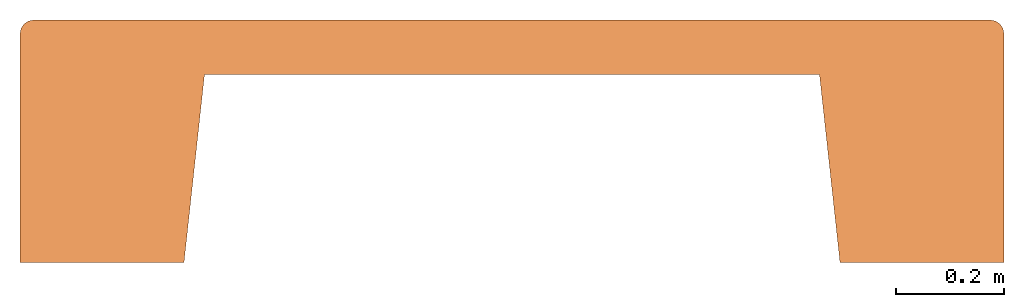
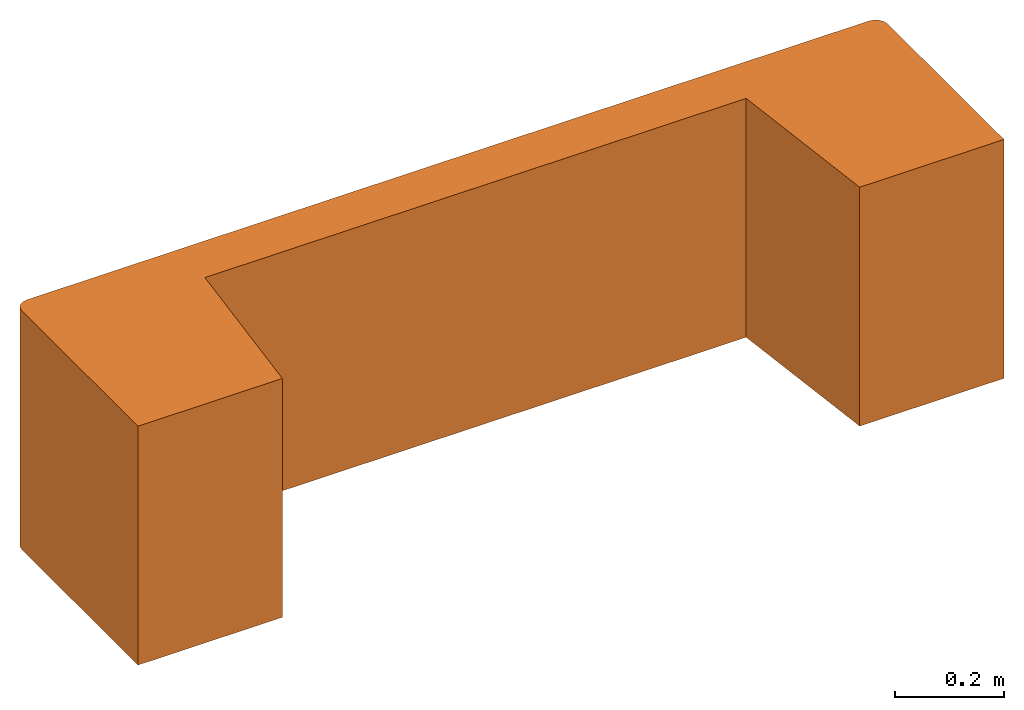
# One storey: 1 proxy.
"""IFC2X3 building model written with IfcOpenShell, lengths in metres."""

from ifc_helpers import new_model, si_unit, direction, origin_with_axes, place, context, project, spatial, faceted_brep, source, transform, mapped, material, element, save


model = new_model("IFC2X3")

# Units and contexts
model_context = context("Model", 3, precision=1e-06, world=origin_with_axes(), true_north=direction((0.0, 1.0, 0.0)))
ifc_project = project(units=[si_unit("LENGTHUNIT", "METRE"), si_unit("AREAUNIT", "SQUARE_METRE"), si_unit("VOLUMEUNIT", "CUBIC_METRE")], contexts=[model_context])

# Site, building, storey
site_placement = place(None, origin_with_axes())
site = spatial("IfcSite", under=ifc_project, at=site_placement, CompositionType="ELEMENT")
building_placement = place(site_placement, origin_with_axes())
building = spatial("IfcBuilding", under=site, at=building_placement, Name="Default Building", CompositionType="ELEMENT")
storey_placement = place(building_placement, origin_with_axes())
storey = spatial("IfcBuildingStorey", under=building, at=storey_placement, Name="Default Storey", CompositionType="ELEMENT", Elevation=0.0)

# Proxy
ifc_material = material(Name="Steel")
shared_shape = source(origin_with_axes(), model_context, "Body", "Brep", [
    faceted_brep([(0.6096000075340271, -3.8882534591728874e-17, 0.26669999957084656), (0.5715000033378601, 0.3492499887943268, 0.26669999957084656), (0.6096000075340271, -3.8882534591728874e-17, -0.26669999957084656), (0.6096000075340271, -3.8882534591728874e-17, -0.26669999957084656), (0.5715000033378601, 0.3492499887943268, 0.26669999957084656), (0.5715000033378601, 0.3492499887943268, -0.26669999957084656), (0.9143999814987183, -1.555301383669155e-18, 0.26669999957084656), (0.6096000075340271, -3.8882534591728874e-17, 0.26669999957084656), (0.9143999814987183, -1.555301383669155e-18, -0.26669999957084656), (0.9143999814987183, -1.555301383669155e-18, -0.26669999957084656), (0.6096000075340271, -3.8882534591728874e-17, 0.26669999957084656), (0.6096000075340271, -3.8882534591728874e-17, -0.26669999957084656), (0.9143999814987183, 0.42544999718666077, 0.26669999957084656), (0.9143999814987183, 0.0, 0.26669999957084656), (0.9143999814987183, 0.42544999718666077, -0.26669999957084656), (0.9143999814987183, 0.42544999718666077, -0.26669999957084656), (0.9143999814987183, 0.0, 0.26669999957084656), (0.9143999814987183, 0.0, -0.26669999957084656), (0.8889999985694885, 0.4508500099182129, -0.26669999957084656), (-0.8889999985694885, 0.4508500099182129, -0.26669999957084656), (0.8889999985694885, 0.4508500099182129, 0.26669999957084656), (0.8889999985694885, 0.4508500099182129, 0.26669999957084656), (-0.8889999985694885, 0.4508500099182129, -0.26669999957084656), (-0.8889999985694885, 0.4508500099182129, 0.26669999957084656), (-0.9143999814987183, 0.42544999718666077, -0.26669999957084656), (-0.9143999814987183, 0.0, -0.26669999957084656), (-0.9143999814987183, 0.42544999718666077, 0.26669999957084656), (-0.9143999814987183, 0.42544999718666077, 0.26669999957084656), (-0.9143999814987183, 0.0, -0.26669999957084656), (-0.9143999814987183, 0.0, 0.26669999957084656), (-0.6096000075340271, -3.8882534591728874e-17, 0.26669999957084656), (-0.9143999814987183, -1.555301383669155e-18, 0.26669999957084656), (-0.6096000075340271, -3.8882534591728874e-17, -0.26669999957084656), (-0.6096000075340271, -3.8882534591728874e-17, -0.26669999957084656), (-0.9143999814987183, -1.555301383669155e-18, 0.26669999957084656), (-0.9143999814987183, -1.555301383669155e-18, -0.26669999957084656), (-0.5715000033378601, 0.3492499887943268, 0.26669999957084656), (-0.6096000075340271, -3.8882534591728874e-17, 0.26669999957084656), (-0.5715000033378601, 0.3492499887943268, -0.26669999957084656), (-0.5715000033378601, 0.3492499887943268, -0.26669999957084656), (-0.6096000075340271, -3.8882534591728874e-17, 0.26669999957084656), (-0.6096000075340271, -3.8882534591728874e-17, -0.26669999957084656), (0.5715000033378601, 0.3492499887943268, 0.26669999957084656), (-0.5715000033378601, 0.3492499887943268, 0.26669999957084656), (0.5715000033378601, 0.3492499887943268, -0.26669999957084656), (0.5715000033378601, 0.3492499887943268, -0.26669999957084656), (-0.5715000033378601, 0.3492499887943268, 0.26669999957084656), (-0.5715000033378601, 0.3492499887943268, -0.26669999957084656), (0.5715000033378601, 0.3492499887943268, 0.26669999957084656), (0.6096000075340271, -3.8882534591728874e-17, 0.26669999957084656), (0.9143999814987183, -1.555301383669155e-18, 0.26669999957084656), (-0.9143999814987183, -1.555301383669155e-18, 0.26669999957084656), (-0.6096000075340271, -3.8882534591728874e-17, 0.26669999957084656), (-0.9143999814987183, 0.42544999718666077, 0.26669999957084656), (-0.9143999814987183, 0.42544999718666077, 0.26669999957084656), (-0.6096000075340271, -3.8882534591728874e-17, 0.26669999957084656), (-0.5715000033378601, 0.3492499887943268, 0.26669999957084656), (-0.9143999814987183, 0.42544999718666077, 0.26669999957084656), (-0.5715000033378601, 0.3492499887943268, 0.26669999957084656), (-0.9124665260314941, 0.43517017364501953, 0.26669999957084656), (-0.9124665260314941, 0.43517017364501953, 0.26669999957084656), (-0.5715000033378601, 0.3492499887943268, 0.26669999957084656), (-0.8987201452255249, 0.44891655445098877, 0.26669999957084656), (-0.9124665260314941, 0.43517017364501953, 0.26669999957084656), (-0.8987201452255249, 0.44891655445098877, 0.26669999957084656), (-0.9069604873657227, 0.4434105157852173, 0.26669999957084656), (0.9143999814987183, -1.555301383669155e-18, 0.26669999957084656), (0.9143999814987183, 0.42544999718666077, 0.26669999957084656), (0.5715000033378601, 0.3492499887943268, 0.26669999957084656), (0.5715000033378601, 0.3492499887943268, 0.26669999957084656), (0.9143999814987183, 0.42544999718666077, 0.26669999957084656), (0.9124665260314941, 0.43517017364501953, 0.26669999957084656), (0.5715000033378601, 0.3492499887943268, 0.26669999957084656), (0.9124665260314941, 0.43517017364501953, 0.26669999957084656), (0.9069604873657227, 0.4434105157852173, 0.26669999957084656), (0.9069604873657227, 0.4434105157852173, 0.26669999957084656), (0.8987201452255249, 0.44891655445098877, 0.26669999957084656), (0.5715000033378601, 0.3492499887943268, 0.26669999957084656), (0.5715000033378601, 0.3492499887943268, 0.26669999957084656), (0.8987201452255249, 0.44891655445098877, 0.26669999957084656), (0.8889999985694885, 0.4508500099182129, 0.26669999957084656), (0.5715000033378601, 0.3492499887943268, 0.26669999957084656), (0.8889999985694885, 0.4508500099182129, 0.26669999957084656), (-0.5715000033378601, 0.3492499887943268, 0.26669999957084656), (-0.5715000033378601, 0.3492499887943268, 0.26669999957084656), (0.8889999985694885, 0.4508500099182129, 0.26669999957084656), (-0.8889999985694885, 0.4508500099182129, 0.26669999957084656), (-0.5715000033378601, 0.3492499887943268, 0.26669999957084656), (-0.8889999985694885, 0.4508500099182129, 0.26669999957084656), (-0.8987201452255249, 0.44891655445098877, 0.26669999957084656), (0.9143999814987183, -1.555301383669155e-18, -0.26669999957084656), (0.6096000075340271, -3.8882534591728874e-17, -0.26669999957084656), (0.9143999814987183, 0.42544999718666077, -0.26669999957084656), (0.9143999814987183, 0.42544999718666077, -0.26669999957084656), (0.6096000075340271, -3.8882534591728874e-17, -0.26669999957084656), (0.5715000033378601, 0.3492499887943268, -0.26669999957084656), (0.9143999814987183, 0.42544999718666077, -0.26669999957084656), (0.5715000033378601, 0.3492499887943268, -0.26669999957084656), (0.9124665260314941, 0.43517017364501953, -0.26669999957084656), (-0.6096000075340271, -3.8882534591728874e-17, -0.26669999957084656), (-0.9143999814987183, -1.555301383669155e-18, -0.26669999957084656), (-0.5715000033378601, 0.3492499887943268, -0.26669999957084656), (-0.5715000033378601, 0.3492499887943268, -0.26669999957084656), (-0.9143999814987183, -1.555301383669155e-18, -0.26669999957084656), (-0.9143999814987183, 0.42544999718666077, -0.26669999957084656), (-0.5715000033378601, 0.3492499887943268, -0.26669999957084656), (-0.9143999814987183, 0.42544999718666077, -0.26669999957084656), (-0.9124665260314941, 0.43517017364501953, -0.26669999957084656), (0.9069604873657227, 0.4434105157852173, -0.26669999957084656), (0.9124665260314941, 0.43517017364501953, -0.26669999957084656), (0.8987201452255249, 0.44891655445098877, -0.26669999957084656), (0.8987201452255249, 0.44891655445098877, -0.26669999957084656), (0.9124665260314941, 0.43517017364501953, -0.26669999957084656), (0.5715000033378601, 0.3492499887943268, -0.26669999957084656), (0.8987201452255249, 0.44891655445098877, -0.26669999957084656), (0.5715000033378601, 0.3492499887943268, -0.26669999957084656), (0.8889999985694885, 0.4508500099182129, -0.26669999957084656), (0.8889999985694885, 0.4508500099182129, -0.26669999957084656), (0.5715000033378601, 0.3492499887943268, -0.26669999957084656), (-0.5715000033378601, 0.3492499887943268, -0.26669999957084656), (0.8889999985694885, 0.4508500099182129, -0.26669999957084656), (-0.5715000033378601, 0.3492499887943268, -0.26669999957084656), (-0.8889999985694885, 0.4508500099182129, -0.26669999957084656), (-0.9124665260314941, 0.43517017364501953, -0.26669999957084656), (-0.9069604873657227, 0.4434105157852173, -0.26669999957084656), (-0.5715000033378601, 0.3492499887943268, -0.26669999957084656), (-0.5715000033378601, 0.3492499887943268, -0.26669999957084656), (-0.9069604873657227, 0.4434105157852173, -0.26669999957084656), (-0.8987201452255249, 0.44891655445098877, -0.26669999957084656), (-0.5715000033378601, 0.3492499887943268, -0.26669999957084656), (-0.8987201452255249, 0.44891655445098877, -0.26669999957084656), (-0.8889999985694885, 0.4508500099182129, -0.26669999957084656), (0.9143999814987183, 0.42544999718666077, 0.26669999957084656), (0.9143999814987183, 0.42544999718666077, -0.26669999957084656), (0.9124665260314941, 0.43517017364501953, -0.26669999957084656), (0.9143999814987183, 0.42544999718666077, 0.26669999957084656), (0.9124665260314941, 0.43517017364501953, -0.26669999957084656), (0.9124665260314941, 0.43517017364501953, 0.26669999957084656), (0.9124665260314941, 0.43517017364501953, 0.26669999957084656), (0.9124665260314941, 0.43517017364501953, -0.26669999957084656), (0.9069604873657227, 0.4434105157852173, -0.26669999957084656), (0.9124665260314941, 0.43517017364501953, 0.26669999957084656), (0.9069604873657227, 0.4434105157852173, -0.26669999957084656), (0.9069604873657227, 0.4434105157852173, 0.26669999957084656), (0.9069604873657227, 0.4434105157852173, 0.26669999957084656), (0.9069604873657227, 0.4434105157852173, -0.26669999957084656), (0.8987201452255249, 0.44891655445098877, -0.26669999957084656), (0.9069604873657227, 0.4434105157852173, 0.26669999957084656), (0.8987201452255249, 0.44891655445098877, -0.26669999957084656), (0.8987201452255249, 0.44891655445098877, 0.26669999957084656), (0.8987201452255249, 0.44891655445098877, 0.26669999957084656), (0.8987201452255249, 0.44891655445098877, -0.26669999957084656), (0.8889999985694885, 0.4508500099182129, -0.26669999957084656), (0.8987201452255249, 0.44891655445098877, 0.26669999957084656), (0.8889999985694885, 0.4508500099182129, -0.26669999957084656), (0.8889999985694885, 0.4508500099182129, 0.26669999957084656), (-0.8889999985694885, 0.4508500099182129, 0.26669999957084656), (-0.8889999985694885, 0.4508500099182129, -0.26669999957084656), (-0.8987201452255249, 0.44891655445098877, -0.26669999957084656), (-0.8889999985694885, 0.4508500099182129, 0.26669999957084656), (-0.8987201452255249, 0.44891655445098877, -0.26669999957084656), (-0.8987201452255249, 0.44891655445098877, 0.26669999957084656), (-0.8987201452255249, 0.44891655445098877, 0.26669999957084656), (-0.8987201452255249, 0.44891655445098877, -0.26669999957084656), (-0.9069604873657227, 0.4434105157852173, -0.26669999957084656), (-0.8987201452255249, 0.44891655445098877, 0.26669999957084656), (-0.9069604873657227, 0.4434105157852173, -0.26669999957084656), (-0.9069604873657227, 0.4434105157852173, 0.26669999957084656), (-0.9069604873657227, 0.4434105157852173, 0.26669999957084656), (-0.9069604873657227, 0.4434105157852173, -0.26669999957084656), (-0.9124665260314941, 0.43517017364501953, -0.26669999957084656), (-0.9069604873657227, 0.4434105157852173, 0.26669999957084656), (-0.9124665260314941, 0.43517017364501953, -0.26669999957084656), (-0.9124665260314941, 0.43517017364501953, 0.26669999957084656), (-0.9124665260314941, 0.43517017364501953, 0.26669999957084656), (-0.9124665260314941, 0.43517017364501953, -0.26669999957084656), (-0.9143999814987183, 0.42544999718666077, -0.26669999957084656), (-0.9124665260314941, 0.43517017364501953, 0.26669999957084656), (-0.9143999814987183, 0.42544999718666077, -0.26669999957084656), (-0.9143999814987183, 0.42544999718666077, 0.26669999957084656)], [[[0, 1, 2]], [[3, 4, 5]], [[6, 7, 8]], [[9, 10, 11]], [[12, 13, 14]], [[15, 16, 17]], [[18, 19, 20]], [[21, 22, 23]], [[24, 25, 26]], [[27, 28, 29]], [[30, 31, 32]], [[33, 34, 35]], [[36, 37, 38]], [[39, 40, 41]], [[42, 43, 44]], [[45, 46, 47]], [[48, 49, 50]], [[51, 52, 53]], [[54, 55, 56]], [[57, 58, 59]], [[60, 61, 62]], [[63, 64, 65]], [[66, 67, 68]], [[69, 70, 71]], [[72, 73, 74]], [[75, 76, 77]], [[78, 79, 80]], [[81, 82, 83]], [[84, 85, 86]], [[87, 88, 89]], [[90, 91, 92]], [[93, 94, 95]], [[96, 97, 98]], [[99, 100, 101]], [[102, 103, 104]], [[105, 106, 107]], [[108, 109, 110]], [[111, 112, 113]], [[114, 115, 116]], [[117, 118, 119]], [[120, 121, 122]], [[123, 124, 125]], [[126, 127, 128]], [[129, 130, 131]], [[132, 133, 134]], [[135, 136, 137]], [[138, 139, 140]], [[141, 142, 143]], [[144, 145, 146]], [[147, 148, 149]], [[150, 151, 152]], [[153, 154, 155]], [[156, 157, 158]], [[159, 160, 161]], [[162, 163, 164]], [[165, 166, 167]], [[168, 169, 170]], [[171, 172, 173]], [[174, 175, 176]], [[177, 178, 179]]]),
])
proxy_placement = place(storey_placement, origin_with_axes())
element("IfcBuildingElementProxy", 1, at=proxy_placement, inside=storey, material=ifc_material, Name="DUSK BENCH 7", ObjectType="DUSK BENCH 7", CompositionType="ELEMENT", context=model_context, shape_type="MappedRepresentation", body=[
    mapped(shared_shape, transform((0.0, 0.0, 0.0), scale=1.0)),
])

save(model, "model.ifc")
